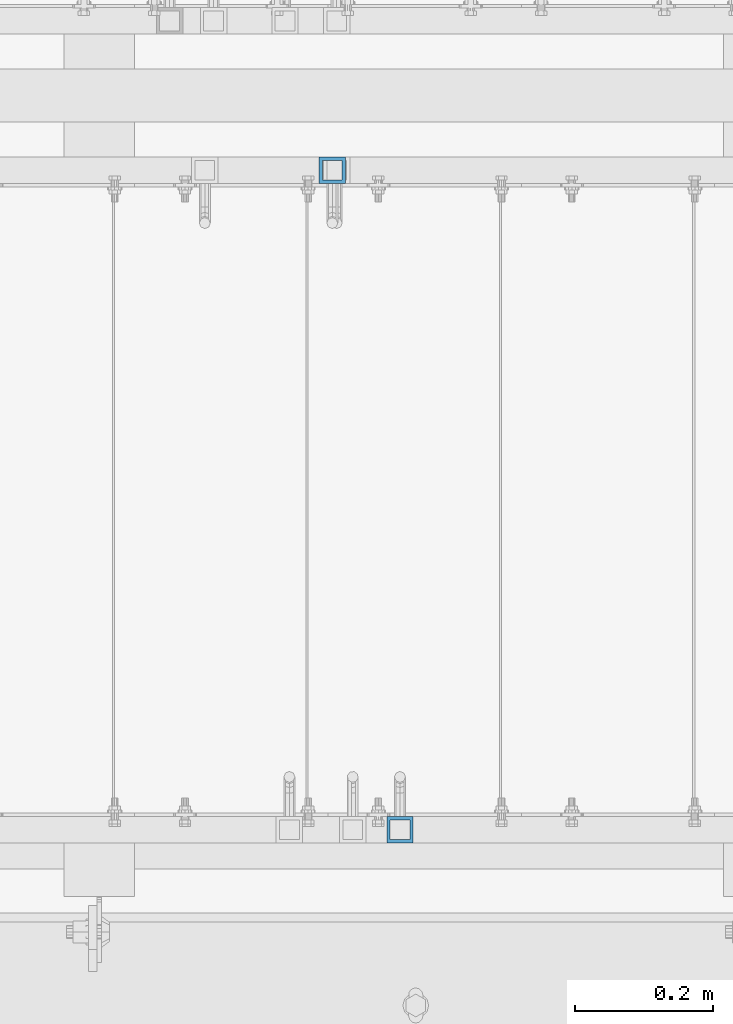
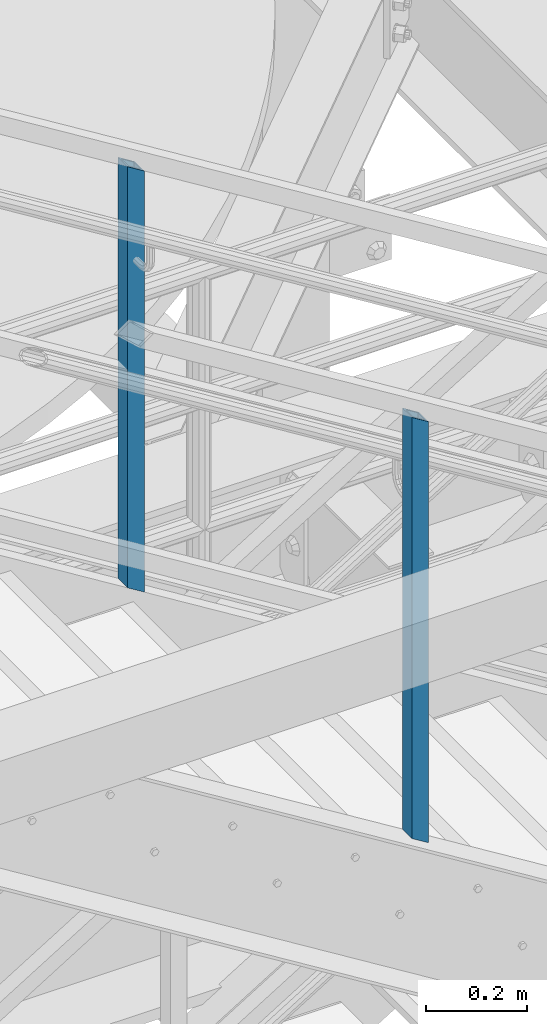
# One storey, part 581 of 1876: 2 columns, 2 elements without a shape of their own.
"""IFC2X3 building model written with IfcOpenShell, lengths in millimetres."""

from ifc_helpers import new_model, si_unit, frame, origin_with_axes, place, context, subcontext, project, spatial, faceted_brep, material, type_object, element, aggregate, save


model = new_model("IFC2X3")

# Units and contexts
model_context = context("Model", 3, precision=1e-05, world=origin_with_axes())
body_context = subcontext(model_context, "Body", "Model", "MODEL_VIEW")
ifc_project = project(units=[si_unit("LENGTHUNIT", "METRE", prefix="MILLI"), si_unit("AREAUNIT", "SQUARE_METRE"), si_unit("VOLUMEUNIT", "CUBIC_METRE"), si_unit("MASSUNIT", "GRAM", prefix="KILO"), si_unit("TIMEUNIT", "SECOND"), si_unit("PLANEANGLEUNIT", "RADIAN"), si_unit("SOLIDANGLEUNIT", "STERADIAN"), si_unit("THERMODYNAMICTEMPERATUREUNIT", "DEGREE_CELSIUS"), si_unit("LUMINOUSINTENSITYUNIT", "LUMEN")], contexts=[model_context])

# Site, building, storey
site_placement = place(None, origin_with_axes())
site = spatial("IfcSite", under=ifc_project, at=site_placement, CompositionType="ELEMENT")
building_placement = place(site_placement, origin_with_axes())
building = spatial("IfcBuilding", under=site, at=building_placement, Name="Undefined", CompositionType="ELEMENT")
storey_placement = place(building_placement, origin_with_axes())
storey = spatial("IfcBuildingStorey", under=building, at=storey_placement, Name="Undefined", CompositionType="ELEMENT", Elevation=0.0)

# Assembly, column
assembly_1_placement = place(storey_placement, origin_with_axes())
assembly_1 = element("IfcElementAssembly", 1, at=assembly_1_placement, inside=storey, Name="RAIL", AssemblyPlace="NOTDEFINED", PredefinedType="RIGID_FRAME")
ifc_material = material()
column_type = type_object("IfcColumnType", Name="HSS1-1/2X1-1/2X3/16", PredefinedType="NOTDEFINED")
column_1_placement = place(assembly_1_placement, frame((4244.34000046609, -6902.45000114049, 14669.2566834289), z_axis=(1.0, 0.0, 0.0), x_axis=(0.0, 0.0, 1.0)))
column_1 = element("IfcColumn", 2, at=column_1_placement, type_object=column_type, material=ifc_material, Name="POST", ObjectType="HSS1-1/2X1-1/2X3/16", context=body_context, shape_type="Brep", body=[
    faceted_brep([(1026.31295131947, -19.0499999945778, -19.0499992349996), (1026.31295131947, 19.0499992349996, -19.0499992349996), (1002.70890059182, 19.0499992349996, 19.0499992349996), (1002.70890059182, -19.0499992349996, 19.0499992349996), (1023.36244497843, -14.2874994260001, -14.2874994260001), (1005.65940693302, -14.2874994260001, 14.2874994260001), (1005.65940693302, 14.2874994260001, 14.2874994260001), (1023.36244497843, 14.2874994260001, -14.2874994260001), (-11.8020253644645, 19.0499992349996, 19.0499992350001), (-11.8020253644645, -19.0499992349996, 19.0499992350001), (11.8020253632003, -19.0499992349996, -19.0499992350001), (11.8020253632003, 19.0499992349996, -19.0499992350001), (-8.85151902335201, 14.2874994260001, 14.2874994260001), (-8.85151902335201, -14.2874994260001, 14.2874994260001), (8.85151902208599, -14.2874994260001, -14.2874994260001), (8.85151902208599, 14.2874994260001, -14.2874994260001)], [[[0, 1, 2, 3], [4, 5, 6, 7]], [[8, 9, 3, 2]], [[9, 10, 0, 3]], [[10, 11, 1, 0]], [[11, 8, 2, 1]], [[10, 9, 8, 11], [12, 13, 14, 15]], [[15, 14, 4, 7]], [[12, 15, 7, 6]], [[13, 12, 6, 5]], [[14, 13, 5, 4]]]),
])
aggregate(assembly_1, [column_1])

assembly_2_placement = place(storey_placement, origin_with_axes())
assembly_2 = element("IfcElementAssembly", 3, at=assembly_2_placement, inside=storey, Name="RAIL", AssemblyPlace="NOTDEFINED", PredefinedType="RIGID_FRAME")
column_2_placement = place(assembly_2_placement, frame((4146.55000058227, -5949.95000114554, 14729.8404159926), z_axis=(1.0, 0.0, 0.0), x_axis=(0.0, 0.0, 1.0)))
column_2 = element("IfcColumn", 4, at=column_2_placement, type_object=column_type, material=ifc_material, Name="POST", ObjectType="HSS1-1/2X1-1/2X3/16", context=body_context, shape_type="Brep", body=[
    faceted_brep([(1026.31295131947, -19.0499999945778, -19.0499992349996), (1026.31295131947, 19.0499992349996, -19.0499992349996), (1002.70890059182, 19.0499992349996, 19.0499992349996), (1002.70890059182, -19.0499992349996, 19.0499992349996), (1023.36244497843, -14.2874994260001, -14.2874994260001), (1005.65940693302, -14.2874994260001, 14.2874994260001), (1005.65940693302, 14.2874994260001, 14.2874994260001), (1023.36244497843, 14.2874994260001, -14.2874994260001), (-11.8020253644645, 19.0499992349996, 19.0499992350001), (-11.8020253644645, -19.0499992349996, 19.0499992350001), (11.8020253632003, -19.0499992349996, -19.0499992350001), (11.8020253632003, 19.0499992349996, -19.0499992350001), (-8.85151902335201, 14.2874994260001, 14.2874994260001), (-8.85151902335201, -14.2874994260001, 14.2874994260001), (8.85151902208599, -14.2874994260001, -14.2874994260001), (8.85151902208599, 14.2874994260001, -14.2874994260001)], [[[0, 1, 2, 3], [4, 5, 6, 7]], [[8, 9, 3, 2]], [[9, 10, 0, 3]], [[10, 11, 1, 0]], [[11, 8, 2, 1]], [[10, 9, 8, 11], [12, 13, 14, 15]], [[15, 14, 4, 7]], [[12, 15, 7, 6]], [[13, 12, 6, 5]], [[14, 13, 5, 4]]]),
])
aggregate(assembly_2, [column_2])

save(model, "model.ifc")
